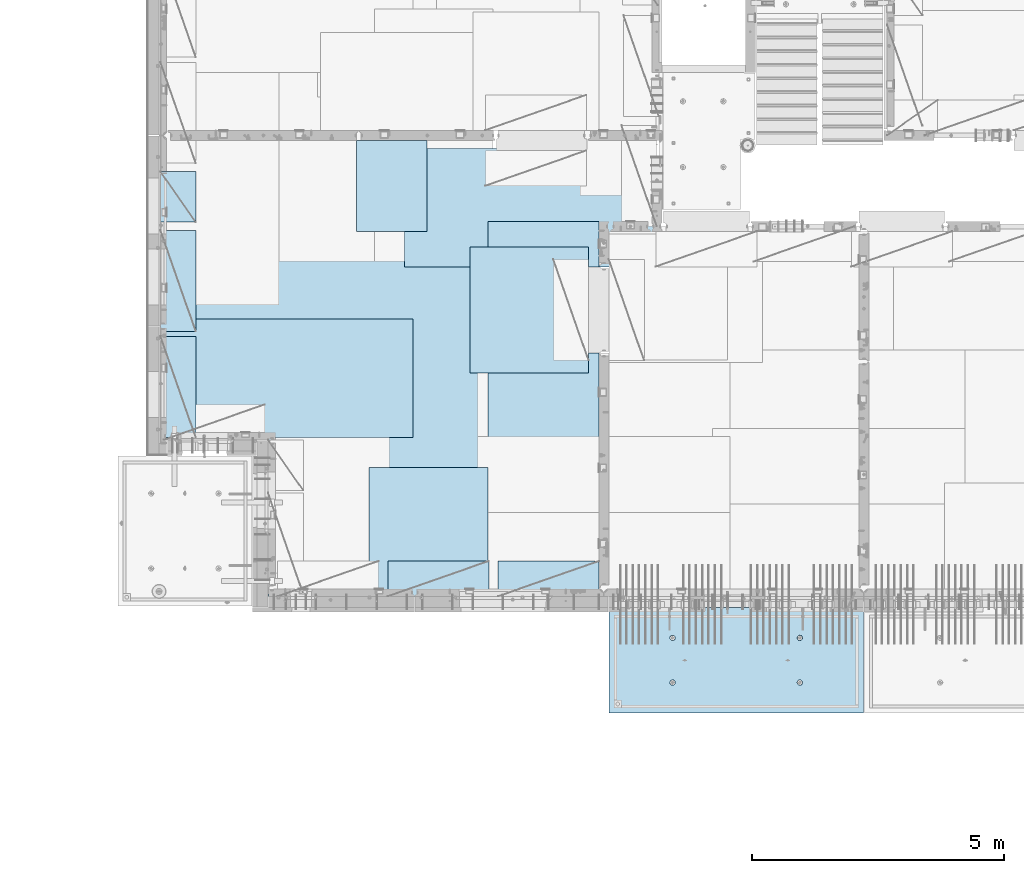
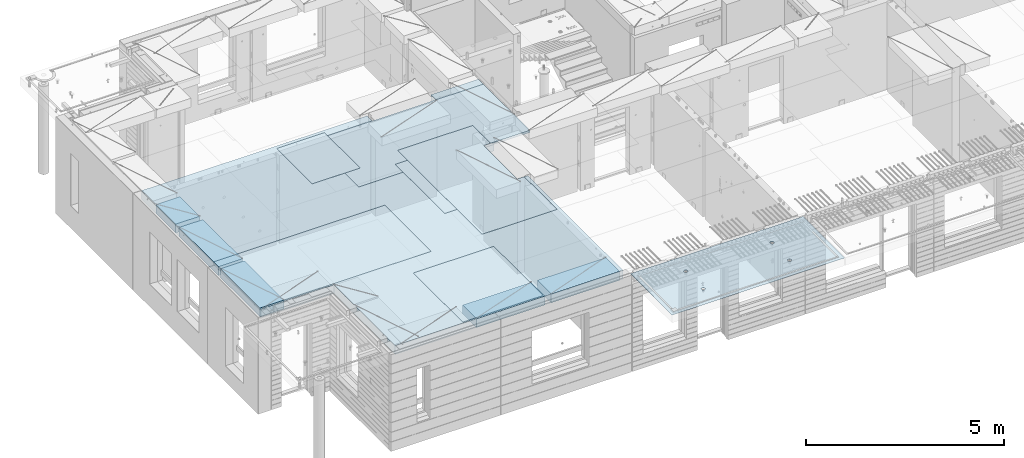
# One storey, part 194 of 341: 11 plates, 2 slabs, 11 elements without a shape of their own.
"""IFC2X3 building model written with IfcOpenShell, lengths in millimetres."""

from ifc_helpers import new_model, si_unit, frame, origin_with_axes, place, context, subcontext, project, spatial, faceted_brep, material, type_object, element, aggregate, save


model = new_model("IFC2X3")

# Units and contexts
model_context = context("Model", 3, precision=1e-05, world=origin_with_axes())
body_context = subcontext(model_context, "Body", "Model", "MODEL_VIEW")
ifc_project = project(units=[si_unit("LENGTHUNIT", "METRE", prefix="MILLI"), si_unit("AREAUNIT", "SQUARE_METRE"), si_unit("VOLUMEUNIT", "CUBIC_METRE"), si_unit("MASSUNIT", "GRAM", prefix="KILO"), si_unit("TIMEUNIT", "SECOND"), si_unit("PLANEANGLEUNIT", "RADIAN"), si_unit("SOLIDANGLEUNIT", "STERADIAN"), si_unit("THERMODYNAMICTEMPERATUREUNIT", "DEGREE_CELSIUS"), si_unit("LUMINOUSINTENSITYUNIT", "LUMEN")], contexts=[model_context])

# Site, building, storey
site_placement = place(None, origin_with_axes())
site = spatial("IfcSite", under=ifc_project, at=site_placement, CompositionType="ELEMENT")
building_placement = place(site_placement, origin_with_axes())
building = spatial("IfcBuilding", under=site, at=building_placement, CompositionType="ELEMENT")
storey_placement = place(building_placement, origin_with_axes())
storey = spatial("IfcBuildingStorey", under=building, at=storey_placement, Name="5", CompositionType="ELEMENT", Elevation=0.0)

# Assembly, slab
assembly_1_placement = place(storey_placement, origin_with_axes())
assembly_1 = element("IfcElementAssembly", 1, at=assembly_1_placement, inside=storey, AssemblyPlace="NOTDEFINED", PredefinedType="REINFORCEMENT_UNIT")
ifc_material_1 = material(Name="CONCRETE/C35/45")
slab_type_1 = type_object("IfcSlabType", PredefinedType="NOTDEFINED")
slab_1_placement = place(assembly_1_placement, frame((21799.9998568133, 7629.99655735226, 96720.0), z_axis=(-1.11800000013248e-06, -0.999999999999375, 0.0), x_axis=(-0.999999999999093, 1.34699999998405e-06, 0.0)))
slab_1 = element("IfcSlab", 2, at=slab_1_placement, type_object=slab_type_1, material=ifc_material_1, PredefinedType="FLOOR", context=body_context, shape_type="Brep", body=[
    faceted_brep([(3730.38290548735, -4.08996566387941, 616.12216176429), (3731.90567362447, 10.0, 615.627386703446), (3739.08833473806, 10.0, 629.724200466487), (3737.80580686752, -3.95055250760925, 630.656008831066), (3750.27560641379, 10.0, 640.911502705889), (3749.35118053074, -3.83997377335618, 642.183862123165), (3764.37240055375, 10.0, 648.094202331947), (3763.88889206625, -3.76900584615942, 649.582281527485), (3779.99882472937, 10.0, 650.569206660445), (3779.99882259584, -3.74455690493051, 652.131088126915), (3795.62525566664, 10.0, 648.094245023346), (3796.1087600739, -3.76900542440126, 649.582325494244), (3809.72206942968, 10.0, 640.911583909758), (3810.64649178305, -3.83997297089081, 642.183945778786), (3820.90937166908, 10.0, 629.724312234022), (3822.19189689232, -3.95055140258046, 630.656124028656), (3828.09207129514, 10.0, 615.627518094066), (3829.61483794004, -4.08996436404414, 616.122297269464), (3830.56707562364, 10.0, 600.001093918447), (3832.18578061358, -4.24460391153116, 600.001096129598), (3828.09211398654, 10.0, 584.374662981175), (3829.64831848373, -4.39934773846471, 583.869023838871), (3820.90945287295, 10.0, 570.277849218135), (3822.24608208202, -4.53903372617788, 569.306734043194), (3809.72218119721, 10.0, 559.090546978732), (3810.70070853473, -4.64994969953841, 557.743723511573), (3795.62538705726, 10.0, 551.907847352675), (3796.14233218844, -4.72119045964791, 550.316861227655), (3779.99896288164, 10.0, 549.432843024176), (3779.99896517058, -4.74574361447594, 547.757190340714), (3764.37253194437, 10.0, 551.907804661275), (3763.85559114489, -4.72119088313775, 550.316817078197), (3750.27571818133, 10.0, 559.090465774863), (3749.29719446955, -4.6499505048414, 557.743639560339), (3739.08841594193, 10.0, 570.277737450599), (3737.75178928409, -4.53903483404429, 569.306618549992), (3731.90571631587, 10.0, 584.374531590555), (3730.34951305942, -4.39934904004622, 583.868888150996), (3729.43071198737, 10.0, 600.000955766174), (3727.81200684201, -4.24460527917836, 600.000953555023), (0.0, 10.0, 0.0), (0.0, -10.0, 0.0), (0.000328360383718973, 10.0, 2085.00366210938), (5040.0, 10.0, -2.18278728425503e-09), (5040.0, -10.0, -2.18278728425503e-09), (5040.00048828125, 10.0, 2085.00366210938), (1210.18496592851, 4.0893025782425, 1468.8123736889), (1210.82376192895, 10.0, 1469.01993205604), (1208.29313952565, 10.0, 1484.99751183111), (1207.63911173254, 4.24455542066426, 1484.99751093771), (1217.61159442581, 3.94915724093153, 1454.20219661341), (1218.16787053537, 10.0, 1454.6063560253), (1229.19498209749, 3.837876675796, 1442.60117732261), (1229.60657282509, 10.0, 1443.16768498606), (1243.80127350603, 3.76640192835475, 1435.14992181469), (1244.02016891989, 10.0, 1435.82361575756), (1259.99775658, 3.74176842256566, 1432.58187432577), (1259.99775560856, 10.0, 1433.29303700502), (1276.19423262309, 3.76640235324157, 1435.14996610939), (1275.97533538363, 10.0, 1435.82365940832), (1290.8005036357, 3.83787748374743, 1442.60126155003), (1290.38891141437, 10.0, 1443.16776801473), (1302.38385956513, 3.94915835243592, 1454.20231248656), (1301.82758245361, 10.0, 1454.60647030446), (1309.81044810845, 4.08930388411682, 1468.81250982317), (1309.17165168211, 10.0, 1469.02006639926), (1312.35625807182, 4.244556792808, 1484.99765398133), (1311.70223043464, 10.0, 1484.99765308793), (1309.77685741928, 4.39970507899125, 1501.17189122433), (1309.17160803135, 10.0, 1500.975232863), (1302.32949611505, 4.53957668620569, 1515.75353188573), (1301.82749942493, 10.0, 1515.38880889374), (1290.74610851982, 4.65051890275208, 1527.31927827547), (1290.3887971352, 10.0, 1526.82747993297), (1276.16055006181, 4.72171992080985, 1534.74199744468), (1275.97520104041, 10.0, 1534.17154916147), (1259.99761353621, 4.74624887190294, 1537.29914508766), (1259.99761435174, 10.0, 1536.70212791401), (1243.83468398195, 4.72171949766926, 1534.74195333328), (1244.02003457667, 10.0, 1534.17150551072), (1229.24914576394, 4.65051809765282, 1527.31919434463), (1229.60645854592, 10.0, 1526.8273969043), (1217.66578971822, 4.53957557752437, 1515.75341630916), (1218.16778750669, 10.0, 1515.38869461457), (1210.21846821205, 4.39970377489226, 1501.17175527336), (1210.82371827819, 10.0, 1500.97509851978), (1210.34950957413, -4.39938207223895, 583.86544460908), (1211.90571640051, 10.0, 584.371089208588), (1209.43071207202, 10.0, 599.997513384207), (1207.81200317426, -4.24463830025343, 599.997511173051), (1217.75178633104, -4.53906787629239, 569.303173961003), (1219.08841602657, 10.0, 570.274295068632), (1229.29719234665, -4.64998355506395, 557.740194139937), (1230.27571826597, 10.0, 559.087023392896), (1243.85559006878, -4.72122393849713, 550.313371123784), (1244.37253202901, 10.0, 551.904362279308), (1259.99896525523, -4.74577667158155, 547.753744202259), (1259.99896296629, 10.0, 549.429400642209), (1276.14233343384, -4.72122351497819, 550.313415273247), (1275.6253871419, 10.0, 551.904404970708), (1290.70071082692, -4.64998274977552, 557.740278091178), (1289.72218128186, 10.0, 559.087104596765), (1302.24608520437, -4.53906676842598, 569.303289454215), (1300.9094529576, 10.0, 570.274406836168), (1309.64832213832, -4.39938077065744, 583.865580296964), (1308.09211407118, 10.0, 584.371220599208), (1312.18578445062, -4.24463693260623, 599.997653747636), (1310.56707570828, 10.0, 599.99765153648), (1309.61484159223, -4.08999737400154, 616.118856046664), (1308.09207137979, 10.0, 615.624075712099), (1302.19190001076, -3.95058440251159, 630.652683850883), (1300.90937175373, 10.0, 629.720869852055), (1290.64649407134, -3.8400059628766, 642.180506429899), (1289.72206951433, 10.0, 640.908141527791), (1276.10876131689, -3.76903841129388, 649.578886677323), (1275.62525575129, 10.0, 648.090802641378), (1259.99882268048, -3.74458989004779, 652.127649493255), (1259.99882481401, 10.0, 650.565764278478), (1243.88889099253, -3.76903883303748, 649.578842710559), (1244.37240063839, 10.0, 648.090759949978), (1229.35117841172, -3.84000676534197, 642.180422774271), (1230.27560649844, 10.0, 640.908060323922), (1217.80580391836, -3.95058550754038, 630.652568653284), (1219.0883348227, 10.0, 629.72075808452), (1210.38290200446, -4.08999867383682, 616.11872054148), (1211.90567370912, 10.0, 615.623944321479), (3795.97520095576, 10.0, 1534.17499154344), (3796.16054881881, 4.72175290768791, 1534.7454362616), (3779.99761345157, 4.74628185702022, 1537.30258372132), (3779.99761426709, 10.0, 1536.70557029598), (3810.38879705055, 10.0, 1526.83092231494), (3810.74610623151, 4.65055189473787, 1527.32271762435), (3821.82749934028, 10.0, 1515.39225127571), (3822.3294929966, 4.53960968612228, 1515.75697206351), (3829.1716079467, 10.0, 1500.97867524496), (3829.7768537671, 4.39973808894865, 1501.17533244712), (3831.70223035, 10.0, 1485.00109546989), (3832.35625423479, 4.24458981388307, 1485.00109636329), (3829.17165159746, 10.0, 1469.02350878122), (3829.81044445387, 4.08933691630955, 1468.81595336508), (3821.82758236896, 10.0, 1454.60991268643), (3822.38385644279, 3.94919139468402, 1454.20575707554), (3810.38891132972, 10.0, 1443.1712103967), (3810.8005013435, 3.83791053396999, 1442.60470697043), (3795.97533529899, 10.0, 1435.82710179029), (3796.19423137769, 3.76643540860096, 1435.1534120638), (3779.99775552391, 10.0, 1433.29647938699), (3779.99775649536, 3.74180147968582, 1432.58532046422), (3764.02016883524, 10.0, 1435.82705813953), (3763.80127458214, 3.76643498368503, 1435.1533677691), (3749.60657274045, 10.0, 1443.17112736803), (3749.19498422039, 3.837909726004, 1442.60462274301), (3738.16787045072, 10.0, 1454.60979840726), (3737.61159737886, 3.94919028317963, 1454.2056412024), (3730.82376184431, 10.0, 1469.023374438), (3730.18496941381, 4.08933561044978, 1468.81581723082), (3737.66579266739, 4.53960857747006, 1515.75685648694), (3749.24914788297, 4.65055108962406, 1527.32263369353), (3763.83468505566, 4.72175248454732, 1534.7453921502), (3727.63911540029, 4.24458844172477, 1485.00095331968), (3730.21847169495, 4.39973678484967, 1501.17519649617), (3764.02003449202, 10.0, 1534.17494789268), (3749.60645846128, 10.0, 1526.83083928627), (3738.16778742204, 10.0, 1515.39213699654), (3730.82371819355, 10.0, 1500.97854090175), (3728.293139441, 10.0, 1485.00095421308)], [[[0, 1, 2, 3]], [[3, 2, 4, 5]], [[5, 4, 6, 7]], [[7, 6, 8, 9]], [[10, 11, 9, 8]], [[12, 13, 11, 10]], [[14, 15, 13, 12]], [[16, 17, 15, 14]], [[18, 19, 17, 16]], [[20, 21, 19, 18]], [[22, 23, 21, 20]], [[24, 25, 23, 22]], [[26, 27, 25, 24]], [[27, 26, 28, 29]], [[29, 28, 30, 31]], [[31, 30, 32, 33]], [[33, 32, 34, 35]], [[35, 34, 36, 37]], [[37, 36, 38, 39]], [[39, 38, 1, 0]], [[40, 41, 42]], [[40, 43, 44, 41]], [[43, 45, 44]], [[46, 47, 48, 49]], [[50, 51, 47, 46]], [[52, 53, 51, 50]], [[54, 55, 53, 52]], [[56, 57, 55, 54]], [[58, 59, 57, 56]], [[60, 61, 59, 58]], [[61, 60, 62, 63]], [[63, 62, 64, 65]], [[65, 64, 66, 67]], [[67, 66, 68, 69]], [[69, 68, 70, 71]], [[71, 70, 72, 73]], [[73, 72, 74, 75]], [[75, 74, 76, 77]], [[77, 76, 78, 79]], [[80, 81, 79, 78]], [[82, 83, 81, 80]], [[84, 85, 83, 82]], [[49, 48, 85, 84]], [[86, 87, 88, 89]], [[90, 91, 87, 86]], [[92, 93, 91, 90]], [[94, 95, 93, 92]], [[96, 97, 95, 94]], [[98, 99, 97, 96]], [[99, 98, 100, 101]], [[101, 100, 102, 103]], [[103, 102, 104, 105]], [[105, 104, 106, 107]], [[107, 106, 108, 109]], [[109, 108, 110, 111]], [[111, 110, 112, 113]], [[113, 112, 114, 115]], [[115, 114, 116, 117]], [[118, 119, 117, 116]], [[120, 121, 119, 118]], [[122, 123, 121, 120]], [[124, 125, 123, 122]], [[89, 88, 125, 124]], [[126, 127, 128, 129]], [[130, 131, 127, 126]], [[132, 133, 131, 130]], [[134, 135, 133, 132]], [[136, 137, 135, 134]], [[138, 139, 137, 136]], [[140, 141, 139, 138]], [[142, 143, 141, 140]], [[143, 142, 144, 145]], [[145, 144, 146, 147]], [[147, 146, 148, 149]], [[149, 148, 150, 151]], [[151, 150, 152, 153]], [[153, 152, 154, 155]], [[41, 44, 45, 42], [3, 5, 7, 9, 11, 13, 15, 17, 19, 21, 23, 25, 27, 29, 31, 33, 35, 37, 39, 0], [156, 157, 158, 128, 127, 131, 133, 135, 137, 139, 141, 143, 145, 147, 149, 151, 153, 155, 159, 160], [122, 120, 118, 116, 114, 112, 110, 108, 106, 104, 102, 100, 98, 96, 94, 92, 90, 86, 89, 124], [82, 80, 78, 76, 74, 72, 70, 68, 66, 64, 62, 60, 58, 56, 54, 52, 50, 46, 49, 84]], [[129, 128, 158, 161]], [[157, 162, 161, 158]], [[156, 163, 162, 157]], [[160, 164, 163, 156]], [[159, 165, 164, 160]], [[155, 154, 165, 159]], [[43, 40, 42, 45], [34, 32, 30, 28, 26, 24, 22, 20, 18, 16, 14, 12, 10, 8, 6, 4, 2, 1, 38, 36], [152, 150, 148, 146, 144, 142, 140, 138, 136, 134, 132, 130, 126, 129, 161, 162, 163, 164, 165, 154], [91, 93, 95, 97, 99, 101, 103, 105, 107, 109, 111, 113, 115, 117, 119, 121, 123, 125, 88, 87], [51, 53, 55, 57, 59, 61, 63, 65, 67, 69, 71, 73, 75, 77, 79, 81, 83, 85, 48, 47]]]),
])
aggregate(assembly_1, [slab_1])

# Assembly, plate
assembly_2_placement = place(storey_placement, origin_with_axes())
assembly_2 = element("IfcElementAssembly", 3, at=assembly_2_placement, inside=storey, Name="Steel Assembly", AssemblyPlace="NOTDEFINED", PredefinedType="NOTDEFINED")
ifc_material_2 = material()
plate_type_1 = type_object("IfcPlateType", PredefinedType="NOTDEFINED")
plate_1_placement = place(assembly_2_placement, frame((14009.7695320312, 12275.0000289158, 96695.1), z_axis=(0.0, 1.0, 0.0), x_axis=(1.0, 0.0, 0.0)))
plate_1 = element("IfcPlate", 4, at=plate_1_placement, type_object=plate_type_1, material=ifc_material_2, Name="1/2", context=body_context, shape_type="Brep", body=[
    faceted_brep([(0.0, -35.0, 0.0), (0.0, -35.0, 2500.0), (0.0, 35.0, 2500.0), (0.0, 35.0, 0.0), (2349.99951171875, -35.0, 2500.0), (2349.99951171875, 35.0, 2500.0), (2350.0, -35.0, 0.0), (2350.0, 35.0, 0.0)], [[[0, 1, 2, 3]], [[1, 4, 5, 2]], [[4, 6, 7, 5]], [[6, 0, 3, 7]], [[5, 7, 3, 2]], [[6, 4, 1, 0]]]),
])
aggregate(assembly_2, [plate_1])

assembly_3_placement = place(storey_placement, origin_with_axes())
assembly_3 = element("IfcElementAssembly", 5, at=assembly_3_placement, inside=storey, Name="Steel Assembly", AssemblyPlace="NOTDEFINED", PredefinedType="NOTDEFINED")
plate_2_placement = place(assembly_3_placement, frame((14360.0, 10400.0, 96695.1), z_axis=(0.0, -1.0, 0.0), x_axis=(-1.0, 3.00000001838171e-08, 0.0)))
plate_2 = element("IfcPlate", 6, at=plate_2_placement, type_object=plate_type_1, material=ifc_material_2, Name="1/2", context=body_context, shape_type="Brep", body=[
    faceted_brep([(0.0, -35.0, 0.0), (0.0, -35.0, 2500.0), (0.0, 35.0, 2500.0), (0.0, 35.0, 0.0), (2349.99951171875, -35.0, 2500.0), (2349.99951171875, 35.0, 2500.0), (2350.0, -35.0, 0.0), (2350.0, 35.0, 0.0)], [[[0, 1, 2, 3]], [[1, 4, 5, 2]], [[4, 6, 7, 5]], [[6, 0, 3, 7]], [[5, 7, 3, 2]], [[6, 4, 1, 0]]]),
])
aggregate(assembly_3, [plate_2])

assembly_4_placement = place(storey_placement, origin_with_axes())
assembly_4 = element("IfcElementAssembly", 7, at=assembly_4_placement, inside=storey, Name="Steel Assembly", AssemblyPlace="NOTDEFINED", PredefinedType="NOTDEFINED")
plate_3_placement = place(assembly_4_placement, frame((12710.0, 16725.0, 96695.1), z_axis=(1.0, 0.0, 0.0), x_axis=(0.0, -1.0, 0.0)))
plate_3 = element("IfcPlate", 8, at=plate_3_placement, type_object=plate_type_1, material=ifc_material_2, context=body_context, shape_type="Brep", body=[
    faceted_brep([(0.0, -35.0, 0.0), (0.0, -35.0, 5000.0), (0.0, 35.0, 5000.0), (0.0, 35.0, 0.0), (2349.99951171875, -35.0, 5000.0), (2349.99951171875, 35.0, 5000.0), (2350.0, -35.0, 0.0), (2350.0, 35.0, 0.0)], [[[0, 1, 2, 3]], [[1, 4, 5, 2]], [[4, 6, 7, 5]], [[6, 0, 3, 7]], [[5, 7, 3, 2]], [[6, 4, 1, 0]]]),
])
aggregate(assembly_4, [plate_3])

assembly_5_placement = place(storey_placement, origin_with_axes())
assembly_5 = element("IfcElementAssembly", 9, at=assembly_5_placement, inside=storey, Name="Steel Assembly", AssemblyPlace="NOTDEFINED", PredefinedType="NOTDEFINED")
plate_4_placement = place(assembly_5_placement, frame((12880.0, 11000.0, 96695.1), z_axis=(-1.0, 3.00000001838171e-08, 0.0), x_axis=(0.0, 1.0, 0.0)))
plate_4 = element("IfcPlate", 10, at=plate_4_placement, type_object=plate_type_1, material=ifc_material_2, context=body_context, shape_type="Brep", body=[
    faceted_brep([(0.0, -35.0, 0.0), (0.0, -35.0, 5000.0), (0.0, 35.0, 5000.0), (0.0, 35.0, 0.0), (2349.99951171875, -35.0, 5000.0), (2349.99951171875, 35.0, 5000.0), (2350.0, -35.0, 0.0), (2350.0, 35.0, 0.0)], [[[0, 1, 2, 3]], [[1, 4, 5, 2]], [[4, 6, 7, 5]], [[6, 0, 3, 7]], [[5, 7, 3, 2]], [[6, 4, 1, 0]]]),
])
aggregate(assembly_5, [plate_4])

assembly_6_placement = place(storey_placement, origin_with_axes())
assembly_6 = element("IfcElementAssembly", 11, at=assembly_6_placement, inside=storey, Name="Steel Assembly", AssemblyPlace="NOTDEFINED", PredefinedType="NOTDEFINED")
plate_type_2 = type_object("IfcPlateType", PredefinedType="NOTDEFINED")
plate_5_placement = place(assembly_6_placement, frame((7879.99987792969, 13000.0, 96595.3), z_axis=(1.0, 0.0, 0.0), x_axis=(0.0, -1.0, 0.0)))
plate_5 = element("IfcPlate", 12, at=plate_5_placement, type_object=plate_type_2, material=ifc_material_2, Name="RE1", context=body_context, shape_type="Brep", body=[
    faceted_brep([(1.81898940354586e-12, -135.0, 1.81898940354586e-12), (0.0, -135.0, 699.999999999996), (0.0, 135.0, 699.999999999996), (1.81898940354586e-12, 135.0, 1.81898940354586e-12), (1999.99951171875, -135.0, 699.999999999993), (1999.99951171875, 135.0, 699.999999999993), (2000.0, -135.0, -3.63797880709171e-12), (2000.0, 135.0, -3.63797880709171e-12)], [[[0, 1, 2, 3]], [[1, 4, 5, 2]], [[4, 6, 7, 5]], [[6, 0, 3, 7]], [[5, 7, 3, 2]], [[6, 4, 1, 0]]]),
])
aggregate(assembly_6, [plate_5])

assembly_7_placement = place(storey_placement, origin_with_axes())
assembly_7 = element("IfcElementAssembly", 13, at=assembly_7_placement, inside=storey, Name="Steel Assembly", AssemblyPlace="NOTDEFINED", PredefinedType="NOTDEFINED")
plate_6_placement = place(assembly_7_placement, frame((7879.99999992931, 16265.0, 96595.3), z_axis=(1.0, 0.0, 0.0), x_axis=(0.0, -1.0, 0.0)))
plate_6 = element("IfcPlate", 14, at=plate_6_placement, type_object=plate_type_2, material=ifc_material_2, Name="RE1_1/2", context=body_context, shape_type="Brep", body=[
    faceted_brep([(1.81898940354586e-12, -135.0, 1.81898940354586e-12), (0.0, -135.0, 699.999999999996), (0.0, 135.0, 699.999999999996), (1.81898940354586e-12, 135.0, 1.81898940354586e-12), (999.99951171875, -135.0, 700.0), (999.99951171875, 135.0, 700.0), (1000.0, -135.0, 0.0), (1000.0, 135.0, 0.0)], [[[0, 1, 2, 3]], [[1, 4, 5, 2]], [[4, 6, 7, 5]], [[6, 0, 3, 7]], [[5, 7, 3, 2]], [[6, 4, 1, 0]]]),
])
aggregate(assembly_7, [plate_6])

assembly_8_placement = place(storey_placement, origin_with_axes())
assembly_8 = element("IfcElementAssembly", 15, at=assembly_8_placement, inside=storey, Name="Steel Assembly", AssemblyPlace="NOTDEFINED", PredefinedType="NOTDEFINED")
plate_7_placement = place(assembly_8_placement, frame((14565.0008542386, 7850.00010363356, 96595.3), z_axis=(0.0, 1.0, 0.0), x_axis=(1.0, 0.0, 0.0)))
plate_7 = element("IfcPlate", 16, at=plate_7_placement, type_object=plate_type_2, material=ifc_material_2, Name="RE1", context=body_context, shape_type="Brep", body=[
    faceted_brep([(1.81898940354586e-12, -135.0, 1.81898940354586e-12), (0.0, -135.0, 699.999999999996), (0.0, 135.0, 699.999999999996), (1.81898940354586e-12, 135.0, 1.81898940354586e-12), (1999.99951171875, -135.0, 699.999999999993), (1999.99951171875, 135.0, 699.999999999993), (2000.0, -135.0, -3.63797880709171e-12), (2000.0, 135.0, -3.63797880709171e-12)], [[[0, 1, 2, 3]], [[1, 4, 5, 2]], [[4, 6, 7, 5]], [[6, 0, 3, 7]], [[5, 7, 3, 2]], [[6, 4, 1, 0]]]),
])
aggregate(assembly_8, [plate_7])

assembly_9_placement = place(storey_placement, origin_with_axes())
assembly_9 = element("IfcElementAssembly", 17, at=assembly_9_placement, inside=storey, Name="Steel Assembly", AssemblyPlace="NOTDEFINED", PredefinedType="NOTDEFINED")
plate_8_placement = place(assembly_9_placement, frame((12382.5008542386, 7850.00010363356, 96595.3), z_axis=(0.0, 1.0, 0.0), x_axis=(1.0, 0.0, 0.0)))
plate_8 = element("IfcPlate", 18, at=plate_8_placement, type_object=plate_type_2, material=ifc_material_2, Name="RE1", context=body_context, shape_type="Brep", body=[
    faceted_brep([(1.81898940354586e-12, -135.0, 1.81898940354586e-12), (0.0, -135.0, 699.999999999996), (0.0, 135.0, 699.999999999996), (1.81898940354586e-12, 135.0, 1.81898940354586e-12), (1999.99951171875, -135.0, 699.999999999993), (1999.99951171875, 135.0, 699.999999999993), (2000.0, -135.0, -3.63797880709171e-12), (2000.0, 135.0, -3.63797880709171e-12)], [[[0, 1, 2, 3]], [[1, 4, 5, 2]], [[4, 6, 7, 5]], [[6, 0, 3, 7]], [[5, 7, 3, 2]], [[6, 4, 1, 0]]]),
])
aggregate(assembly_9, [plate_8])

assembly_10_placement = place(storey_placement, origin_with_axes())
assembly_10 = element("IfcElementAssembly", 19, at=assembly_10_placement, inside=storey, Name="Steel Assembly", AssemblyPlace="NOTDEFINED", PredefinedType="NOTDEFINED")
plate_9_placement = place(assembly_10_placement, frame((7879.99987792969, 15100.0, 96595.3), z_axis=(1.0, 0.0, 0.0), x_axis=(0.0, -1.0, 0.0)))
plate_9 = element("IfcPlate", 20, at=plate_9_placement, type_object=plate_type_2, material=ifc_material_2, Name="RE1", context=body_context, shape_type="Brep", body=[
    faceted_brep([(1.81898940354586e-12, -135.0, 1.81898940354586e-12), (0.0, -135.0, 699.999999999996), (0.0, 135.0, 699.999999999996), (1.81898940354586e-12, 135.0, 1.81898940354586e-12), (1999.99951171875, -135.0, 699.999999999993), (1999.99951171875, 135.0, 699.999999999993), (2000.0, -135.0, -3.63797880709171e-12), (2000.0, 135.0, -3.63797880709171e-12)], [[[0, 1, 2, 3]], [[1, 4, 5, 2]], [[4, 6, 7, 5]], [[6, 0, 3, 7]], [[5, 7, 3, 2]], [[6, 4, 1, 0]]]),
])
aggregate(assembly_10, [plate_9])

# Assembly, plates, slab
assembly_11_placement = place(storey_placement, origin_with_axes())
assembly_11 = element("IfcElementAssembly", 21, at=assembly_11_placement, inside=storey, AssemblyPlace="NOTDEFINED", PredefinedType="REINFORCEMENT_UNIT")
plate_type_3 = type_object("IfcPlateType", PredefinedType="NOTDEFINED")
plate_10_placement = place(assembly_11_placement, frame((13159.9998642727, 15079.9997757405, 96725.45), z_axis=(-1.0, 3.00000001838171e-08, 0.0), x_axis=(0.0, 1.0, 0.0)))
plate_10 = element("IfcPlate", 22, at=plate_10_placement, type_object=plate_type_3, material=ifc_material_2, context=body_context, shape_type="Brep", body=[
    faceted_brep([(0.0, -5.0, 0.0), (0.0, -5.0, 1399.99963378906), (0.0, 5.0, 1399.99963378906), (0.0, 5.0, 0.0), (1800.00024414063, -5.0, 1399.99963378906), (1800.00024414063, 5.0, 1399.99963378906), (1800.00024414063, -5.0, 0.0), (1800.00024414063, 5.0, 0.0)], [[[0, 1, 2, 3]], [[1, 4, 5, 2]], [[4, 6, 7, 5]], [[6, 0, 3, 7]], [[5, 7, 3, 2]], [[6, 4, 1, 0]]]),
])
plate_type_4 = type_object("IfcPlateType", PredefinedType="NOTDEFINED")
plate_11_placement = place(assembly_11_placement, frame((16559.9994828029, 15279.9995850056, 96725.45), z_axis=(0.0, -1.0, 0.0), x_axis=(-1.0, 3.00000001838171e-08, 0.0)))
plate_11 = element("IfcPlate", 23, at=plate_11_placement, type_object=plate_type_4, material=ifc_material_2, context=body_context, shape_type="Brep", body=[
    faceted_brep([(0.0, -5.0, 2604.99950854713), (0.0, 5.0, 2604.99950854713), (200.234115600586, 5.0, 2604.99950854713), (200.234115600586, -5.0, 2604.99950854713), (200.234115600586, 5.0, 904.999508547127), (200.234115600586, -5.0, 904.999508547127), (0.0, -5.0, 904.999508547127), (0.0, 5.0, 904.999508547127), (0.0, -5.0, 4271.99951171875), (2191.99951171875, -5.0, 4271.99951171875), (2191.99951171875, 5.0, 4271.99951171875), (0.0, 5.0, 4271.99951171875), (2191.99951171875, -5.0, 0.0), (2191.99951171875, 5.0, 0.0), (0.0, -5.0, 0.0), (0.0, 5.0, 0.0)], [[[0, 1, 2, 3]], [[3, 2, 4, 5]], [[6, 5, 4, 7]], [[8, 9, 10, 11]], [[9, 12, 13, 10]], [[12, 14, 15, 13]], [[15, 14, 6, 7]], [[2, 1, 11, 10, 13, 15, 7, 4]], [[8, 11, 1, 0]], [[14, 12, 9, 8, 0, 3, 5, 6]]]),
])
ifc_material_3 = material(Name="CONCRETE/C30/37")
slab_type_2 = type_object("IfcSlabType", PredefinedType="NOTDEFINED")
slab_2_placement = place(assembly_11_placement, frame((10010.0, 7850.0, 96595.0), z_axis=(0.0, 1.0, 0.0), x_axis=(1.0, 0.0, 0.0)))
slab_2 = element("IfcSlab", 24, at=slab_2_placement, type_object=slab_type_2, material=ifc_material_3, PredefinedType="FLOOR", context=body_context, shape_type="Brep", body=[
    faceted_brep([(4453.68914550781, -135.0, 9130.0), (-2130.0, -135.0, 9130.0), (-2130.0, -135.0, 3100.0), (0.0, -135.0, 3100.0), (1.81898940354586e-12, -135.0, 1.81898940354586e-12), (6650.0, -135.0, 0.0), (6650.0, -135.0, 4825.00007645847), (6349.76536720235, -135.0, 4825.00007645847), (6349.76536720235, -135.0, 6525.00007645847), (6649.99998634297, -135.0, 6525.00007645847), (6650.0, -135.0, 7330.0), (7700.0, -135.0, 7330.0), (7700.0, -135.0, 9130.0), (6319.99914550781, -135.0, 9130.0), (6319.99914550781, -135.0, 8830.0), (6153.68914550781, -135.0, 8830.0), (4520.0, -135.0, 8830.0), (4453.69, -135.0, 8830.0), (-2130.0, 135.0, 9130.0), (4453.68914550781, 135.0, 9130.0), (-2130.0, 135.0, 3100.0), (0.0, 135.0, 3100.0), (1.81898940354586e-12, 135.0, 1.81898940354586e-12), (6650.0, 135.0, 0.0), (6650.0, 135.0, 4825.00007645847), (6349.76536720235, 135.0, 4825.00007645847), (6349.76536720235, 135.0, 6525.00007645847), (6650.0, 135.0, 6525.00007645847), (6650.0, 135.0, 7330.0), (7700.0, 135.0, 7330.0), (7700.0, 135.0, 9130.0), (6319.99914550781, 135.0, 9130.0), (6319.99914550781, 135.0, 8830.0), (6153.68914550781, 135.0, 8830.0), (4520.0, 135.0, 8830.0), (4453.69, 135.0, 8830.0)], [[[0, 1, 2, 3, 4, 5, 6, 7, 8, 9, 10, 11, 12, 13, 14, 15, 16, 17]], [[18, 1, 0, 19]], [[2, 1, 18, 20]], [[3, 2, 20, 21]], [[4, 3, 21, 22]], [[5, 4, 22, 23]], [[5, 23, 24, 6]], [[6, 24, 25, 7]], [[7, 25, 26, 8]], [[9, 8, 26, 27]], [[28, 10, 9, 27]], [[11, 10, 28, 29]], [[12, 11, 29, 30]], [[12, 30, 31, 13]], [[13, 31, 32, 14]], [[15, 14, 32, 33, 34, 16]], [[16, 34, 35, 17]], [[33, 32, 31, 30, 29, 28, 27, 26, 25, 24, 23, 22, 21, 20, 18, 19, 35, 34]], [[0, 17, 35, 19]]]),
])
aggregate(assembly_11, [plate_10, plate_11, slab_2])

save(model, "model.ifc")
